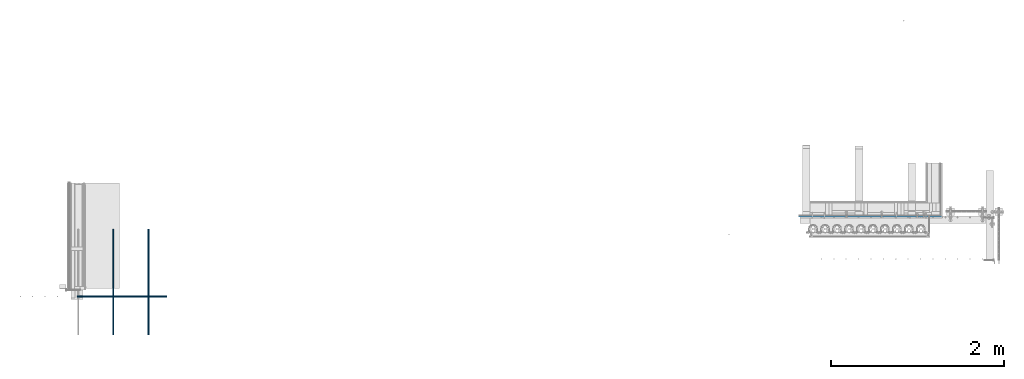
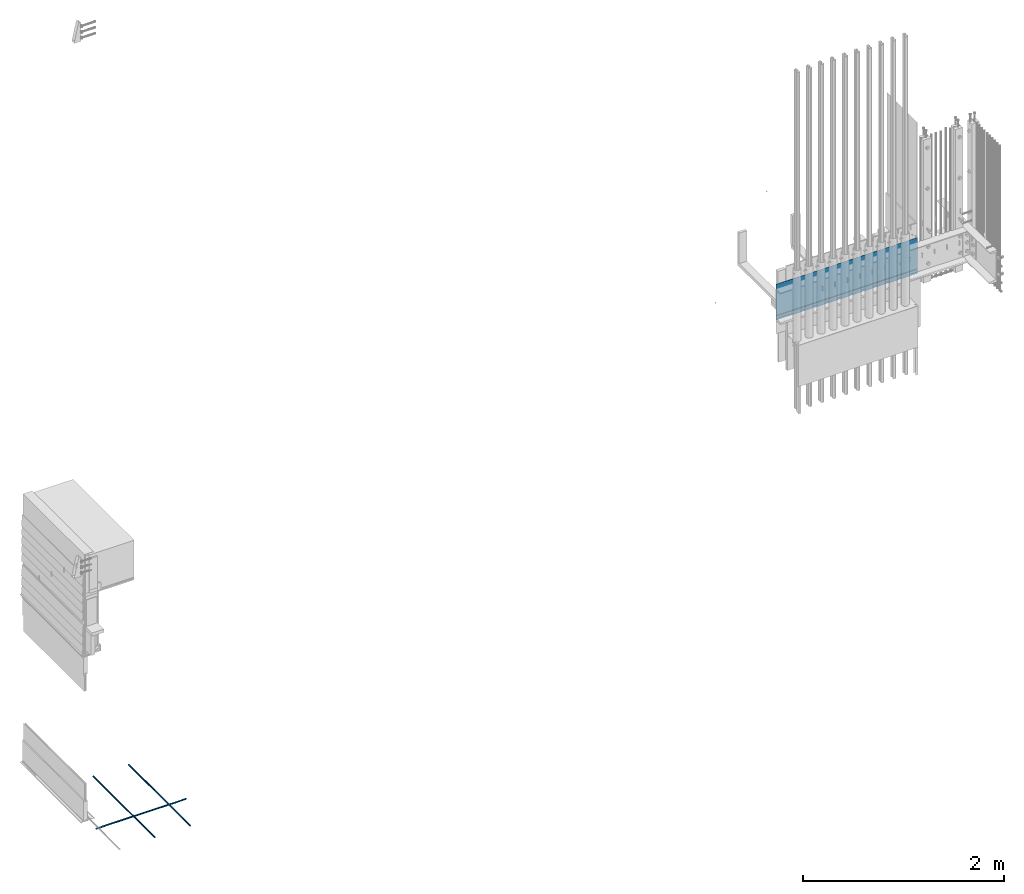
# One storey, part 4 of 44: 4 walls.
"""IFC4 building model written with IfcOpenShell, lengths in feet."""

from ifc_helpers import new_model, entity, si_unit, converted_unit, derived_unit, direction, frame, origin, place, context, subcontext, project, spatial, material, type_object, element, save


model = new_model("IFC4")

# Units and contexts
model_context = context("Model", 3, precision=0.0001, world=origin(), true_north=direction((6.12303176911189e-17, 1.0)))
body_context = subcontext(model_context, "Body", "Model", "MODEL_VIEW")
ifc_project = project(units=[converted_unit("LENGTHUNIT", "FOOT", entity("IfcRatioMeasure", 0.3048), si_unit("LENGTHUNIT", "METRE"), dimensions=[1, 0, 0, 0, 0, 0, 0]), converted_unit("AREAUNIT", "SQUARE FOOT", entity("IfcRatioMeasure", 0.09290304), si_unit("AREAUNIT", "SQUARE_METRE"), dimensions=[2, 0, 0, 0, 0, 0, 0]), converted_unit("VOLUMEUNIT", "CUBIC FOOT", entity("IfcRatioMeasure", 0.028316846592), si_unit("VOLUMEUNIT", "CUBIC_METRE"), dimensions=[3, 0, 0, 0, 0, 0, 0]), converted_unit("PLANEANGLEUNIT", "DEGREE", entity("IfcRatioMeasure", 0.0174532925199433), si_unit("PLANEANGLEUNIT", "RADIAN"), dimensions=[0, 0, 0, 0, 0, 0, 0]), si_unit("MASSUNIT", "GRAM", prefix="KILO"), derived_unit("MASSDENSITYUNIT", [(si_unit("MASSUNIT", "GRAM", prefix="KILO"), 1), (si_unit("LENGTHUNIT", "METRE"), -3)]), derived_unit("MOMENTOFINERTIAUNIT", [(si_unit("LENGTHUNIT", "METRE"), 4)]), si_unit("TIMEUNIT", "SECOND"), si_unit("FREQUENCYUNIT", "HERTZ"), si_unit("THERMODYNAMICTEMPERATUREUNIT", "DEGREE_CELSIUS"), derived_unit("THERMALTRANSMITTANCEUNIT", [(si_unit("MASSUNIT", "GRAM", prefix="KILO"), 1), (si_unit("THERMODYNAMICTEMPERATUREUNIT", "KELVIN"), -1), (si_unit("TIMEUNIT", "SECOND"), -3)]), derived_unit("VOLUMETRICFLOWRATEUNIT", [(si_unit("LENGTHUNIT", "METRE"), 3), (si_unit("TIMEUNIT", "SECOND"), -1)]), si_unit("ELECTRICCURRENTUNIT", "AMPERE"), si_unit("ELECTRICVOLTAGEUNIT", "VOLT"), si_unit("POWERUNIT", "WATT"), si_unit("FORCEUNIT", "NEWTON"), si_unit("ILLUMINANCEUNIT", "LUX"), si_unit("LUMINOUSFLUXUNIT", "LUMEN"), si_unit("LUMINOUSINTENSITYUNIT", "CANDELA"), derived_unit("USERDEFINED", [(si_unit("MASSUNIT", "GRAM", prefix="KILO"), -1), (si_unit("LENGTHUNIT", "METRE"), -2), (si_unit("TIMEUNIT", "SECOND"), 3), (si_unit("LUMINOUSFLUXUNIT", "LUMEN"), 1)]), derived_unit("LINEARVELOCITYUNIT", [(si_unit("LENGTHUNIT", "METRE"), 1), (si_unit("TIMEUNIT", "SECOND"), -1)]), si_unit("PRESSUREUNIT", "PASCAL"), derived_unit("USERDEFINED", [(si_unit("LENGTHUNIT", "METRE"), -2), (si_unit("MASSUNIT", "GRAM", prefix="KILO"), 1), (si_unit("TIMEUNIT", "SECOND"), -2)]), derived_unit("LINEARFORCEUNIT", [(si_unit("MASSUNIT", "GRAM", prefix="KILO"), 1), (si_unit("LENGTHUNIT", "METRE"), 1), (si_unit("TIMEUNIT", "SECOND"), -2), (si_unit("LENGTHUNIT", "METRE"), -1)]), derived_unit("PLANARFORCEUNIT", [(si_unit("MASSUNIT", "GRAM", prefix="KILO"), 1), (si_unit("LENGTHUNIT", "METRE"), 1), (si_unit("TIMEUNIT", "SECOND"), -2), (si_unit("LENGTHUNIT", "METRE"), -2)])], contexts=[model_context])

# Site, building, storey
site_placement = place(None, origin())
site = spatial("IfcSite", under=ifc_project, at=site_placement, CompositionType="ELEMENT")
building_placement = place(site_placement, origin())
building = spatial("IfcBuilding", under=site, at=building_placement, CompositionType="ELEMENT")
storey_placement = place(building_placement, origin())
storey = spatial("IfcBuildingStorey", under=building, at=storey_placement, CompositionType="ELEMENT", Elevation=0.0)

# Walls
ifc_material_1 = material(Category="Materials")
wall_type_1 = type_object("IfcWallType", Name="Generic Models 689:Generic Models 1", PredefinedType="NOTDEFINED", material=ifc_material_1)
wall_1_placement = place(storey_placement, frame((1459.53987375276, 1.67567612110584, -0.187500000009057)))
cartesian_point_1 = entity("IfcCartesianPoint", [0.0, 0.0208333333333333, 0.0])
vertex_point_1 = entity("IfcVertexPoint", cartesian_point_1)
cartesian_point_2 = entity("IfcCartesianPoint", [0.0, 0.0208333333333333, 0.0416666666666667])
vertex_point_2 = entity("IfcVertexPoint", cartesian_point_2)
cartesian_point_3 = entity("IfcCartesianPoint", [0.0, 0.0208333333333333, 0.0208333333333333])
ifc_direction_1 = entity("IfcDirection", [-1.0, 0.0, 0.0])
ifc_direction_2 = entity("IfcDirection", [0.0, 0.0, 1.0])
edge_curve_1 = entity("IfcEdgeCurve", vertex_point_1, vertex_point_2, entity("IfcTrimmedCurve", entity("IfcCircle", entity("IfcAxis2Placement3D", cartesian_point_3, ifc_direction_1, ifc_direction_2), 0.0208333333333333), [cartesian_point_1], [cartesian_point_2], True, "CARTESIAN"), True)
edge_curve_2 = entity("IfcEdgeCurve", vertex_point_2, vertex_point_1, entity("IfcTrimmedCurve", entity("IfcCircle", entity("IfcAxis2Placement3D", cartesian_point_3, ifc_direction_1, ifc_direction_2), 0.0208333333333333), [cartesian_point_2], [cartesian_point_1], True, "CARTESIAN"), True)
cartesian_point_4 = entity("IfcCartesianPoint", [3.393088110593, 0.0208333333333333, 0.0])
vertex_point_3 = entity("IfcVertexPoint", cartesian_point_4)
cartesian_point_5 = entity("IfcCartesianPoint", [3.393088110593, 0.0208333333333335, 0.0416666666666667])
vertex_point_4 = entity("IfcVertexPoint", cartesian_point_5)
cartesian_point_6 = entity("IfcCartesianPoint", [3.393088110593, 0.0208333333333333, 0.0208333333333333])
ifc_direction_3 = entity("IfcDirection", [1.0, 0.0, 0.0])
edge_curve_3 = entity("IfcEdgeCurve", vertex_point_3, vertex_point_4, entity("IfcTrimmedCurve", entity("IfcCircle", entity("IfcAxis2Placement3D", cartesian_point_6, ifc_direction_3, ifc_direction_2), 0.0208333333333333), [cartesian_point_4], [cartesian_point_5], True, "CARTESIAN"), True)
edge_curve_4 = entity("IfcEdgeCurve", vertex_point_4, vertex_point_3, entity("IfcTrimmedCurve", entity("IfcCircle", entity("IfcAxis2Placement3D", cartesian_point_6, ifc_direction_3, ifc_direction_2), 0.0208333333333333), [cartesian_point_5], [cartesian_point_4], True, "CARTESIAN"), True)
edge_curve_5 = entity("IfcEdgeCurve", vertex_point_3, vertex_point_1, entity("IfcTrimmedCurve", entity("IfcLine", cartesian_point_4, entity("IfcVector", ifc_direction_1, 1.0)), [cartesian_point_4], [cartesian_point_1], True, "CARTESIAN"), True)
edge_curve_6 = entity("IfcEdgeCurve", vertex_point_2, vertex_point_4, entity("IfcTrimmedCurve", entity("IfcLine", cartesian_point_5, entity("IfcVector", ifc_direction_3, 1.0)), [cartesian_point_2], [cartesian_point_5], True, "CARTESIAN"), True)
element("IfcWall", 1, at=wall_1_placement, inside=storey, type_object=wall_type_1, material=ifc_material_1, Name="Generic Models 689:Generic Models 1", ObjectType="Generic Models 689:Generic Models 1", PredefinedType="NOTDEFINED", context=body_context, shape_type="AdvancedBrep", body=[
    entity("IfcAdvancedBrep", entity("IfcClosedShell", [entity("IfcAdvancedFace", [entity("IfcFaceOuterBound", entity("IfcEdgeLoop", [entity("IfcOrientedEdge", None, None, edge_curve_1, True), entity("IfcOrientedEdge", None, None, edge_curve_2, True)]), True)], entity("IfcPlane", entity("IfcAxis2Placement3D", cartesian_point_2, ifc_direction_1, entity("IfcDirection", [0.0, 1.0, 0.0]))), True), entity("IfcAdvancedFace", [entity("IfcFaceOuterBound", entity("IfcEdgeLoop", [entity("IfcOrientedEdge", None, None, edge_curve_3, True), entity("IfcOrientedEdge", None, None, edge_curve_4, True)]), True)], entity("IfcPlane", entity("IfcAxis2Placement3D", cartesian_point_5, ifc_direction_3, entity("IfcDirection", [0.0, -1.0, 0.0]))), True), entity("IfcAdvancedFace", [entity("IfcFaceOuterBound", entity("IfcEdgeLoop", [entity("IfcOrientedEdge", None, None, edge_curve_3, False), entity("IfcOrientedEdge", None, None, edge_curve_5, True), entity("IfcOrientedEdge", None, None, edge_curve_2, False), entity("IfcOrientedEdge", None, None, edge_curve_6, True)]), True)], entity("IfcCylindricalSurface", entity("IfcAxis2Placement3D", cartesian_point_3, ifc_direction_3, ifc_direction_2), 0.0208333333333333), True), entity("IfcAdvancedFace", [entity("IfcFaceOuterBound", entity("IfcEdgeLoop", [entity("IfcOrientedEdge", None, None, edge_curve_4, False), entity("IfcOrientedEdge", None, None, edge_curve_6, False), entity("IfcOrientedEdge", None, None, edge_curve_1, False), entity("IfcOrientedEdge", None, None, edge_curve_5, False)]), True)], entity("IfcCylindricalSurface", entity("IfcAxis2Placement3D", cartesian_point_3, ifc_direction_3, ifc_direction_2), 0.0208333333333333), True)])),
])
ifc_material_2 = material(Category="Materials")
wall_type_2 = type_object("IfcWallType", Name="Generic Models 690:Generic Models 1", PredefinedType="NOTDEFINED", material=ifc_material_2)
wall_2_placement = place(storey_placement, frame((1460.89089222076, 0.240276800300759, -0.133241857409347), z_axis=(0.0, 0.0, 1.0), x_axis=(0.0, 1.0, 0.0)))
cartesian_point_7 = entity("IfcCartesianPoint", [4.009723199695, -0.0416666666665151, 0.0208333333333342])
vertex_point_5 = entity("IfcVertexPoint", cartesian_point_7)
cartesian_point_8 = entity("IfcCartesianPoint", [4.009723199695, 0.0, 0.0208333333333342])
vertex_point_6 = entity("IfcVertexPoint", cartesian_point_8)
cartesian_point_9 = entity("IfcCartesianPoint", [4.009723199695, -0.0208333333332575, 0.0208333333333342])
ifc_direction_4 = entity("IfcDirection", [1.0, 0.0, 0.0])
ifc_direction_5 = entity("IfcDirection", [0.0, 1.0, 0.0])
edge_curve_7 = entity("IfcEdgeCurve", vertex_point_5, vertex_point_6, entity("IfcTrimmedCurve", entity("IfcCircle", entity("IfcAxis2Placement3D", cartesian_point_9, ifc_direction_4, ifc_direction_5), 0.0208333333333333), [cartesian_point_7], [cartesian_point_8], True, "CARTESIAN"), True)
edge_curve_8 = entity("IfcEdgeCurve", vertex_point_6, vertex_point_5, entity("IfcTrimmedCurve", entity("IfcCircle", entity("IfcAxis2Placement3D", cartesian_point_9, ifc_direction_4, ifc_direction_5), 0.0208333333333333), [cartesian_point_8], [cartesian_point_7], True, "CARTESIAN"), True)
cartesian_point_10 = entity("IfcCartesianPoint", [0.0, -0.0416666666665151, 0.0208333333333333])
vertex_point_7 = entity("IfcVertexPoint", cartesian_point_10)
cartesian_point_11 = entity("IfcCartesianPoint", [0.0, 0.0, 0.0208333333333334])
vertex_point_8 = entity("IfcVertexPoint", cartesian_point_11)
cartesian_point_12 = entity("IfcCartesianPoint", [0.0, -0.0208333333332575, 0.0208333333333333])
ifc_direction_6 = entity("IfcDirection", [-1.0, 0.0, 0.0])
edge_curve_9 = entity("IfcEdgeCurve", vertex_point_7, vertex_point_8, entity("IfcTrimmedCurve", entity("IfcCircle", entity("IfcAxis2Placement3D", cartesian_point_12, ifc_direction_6, ifc_direction_5), 0.0208333333333333), [cartesian_point_10], [cartesian_point_11], True, "CARTESIAN"), True)
edge_curve_10 = entity("IfcEdgeCurve", vertex_point_8, vertex_point_7, entity("IfcTrimmedCurve", entity("IfcCircle", entity("IfcAxis2Placement3D", cartesian_point_12, ifc_direction_6, ifc_direction_5), 0.0208333333333333), [cartesian_point_11], [cartesian_point_10], True, "CARTESIAN"), True)
edge_curve_11 = entity("IfcEdgeCurve", vertex_point_8, vertex_point_6, entity("IfcTrimmedCurve", entity("IfcLine", cartesian_point_11, entity("IfcVector", ifc_direction_4, 1.0)), [cartesian_point_11], [cartesian_point_8], True, "CARTESIAN"), True)
edge_curve_12 = entity("IfcEdgeCurve", vertex_point_5, vertex_point_7, entity("IfcTrimmedCurve", entity("IfcLine", cartesian_point_10, entity("IfcVector", ifc_direction_6, 1.0)), [cartesian_point_7], [cartesian_point_10], True, "CARTESIAN"), True)
element("IfcWall", 2, at=wall_2_placement, inside=storey, type_object=wall_type_2, material=ifc_material_2, Name="Generic Models 690:Generic Models 1", ObjectType="Generic Models 690:Generic Models 1", PredefinedType="NOTDEFINED", context=body_context, shape_type="AdvancedBrep", body=[
    entity("IfcAdvancedBrep", entity("IfcClosedShell", [entity("IfcAdvancedFace", [entity("IfcFaceOuterBound", entity("IfcEdgeLoop", [entity("IfcOrientedEdge", None, None, edge_curve_7, True), entity("IfcOrientedEdge", None, None, edge_curve_8, True)]), True)], entity("IfcPlane", entity("IfcAxis2Placement3D", cartesian_point_8, ifc_direction_4, entity("IfcDirection", [0.0, 0.0, 1.0]))), True), entity("IfcAdvancedFace", [entity("IfcFaceOuterBound", entity("IfcEdgeLoop", [entity("IfcOrientedEdge", None, None, edge_curve_9, True), entity("IfcOrientedEdge", None, None, edge_curve_10, True)]), True)], entity("IfcPlane", entity("IfcAxis2Placement3D", cartesian_point_11, ifc_direction_6, entity("IfcDirection", [0.0, 0.0, -1.0]))), True), entity("IfcAdvancedFace", [entity("IfcFaceOuterBound", entity("IfcEdgeLoop", [entity("IfcOrientedEdge", None, None, edge_curve_10, False), entity("IfcOrientedEdge", None, None, edge_curve_11, True), entity("IfcOrientedEdge", None, None, edge_curve_7, False), entity("IfcOrientedEdge", None, None, edge_curve_12, True)]), True)], entity("IfcCylindricalSurface", entity("IfcAxis2Placement3D", cartesian_point_9, ifc_direction_6, ifc_direction_5), 0.0208333333333333), True), entity("IfcAdvancedFace", [entity("IfcFaceOuterBound", entity("IfcEdgeLoop", [entity("IfcOrientedEdge", None, None, edge_curve_9, False), entity("IfcOrientedEdge", None, None, edge_curve_12, False), entity("IfcOrientedEdge", None, None, edge_curve_8, False), entity("IfcOrientedEdge", None, None, edge_curve_11, False)]), True)], entity("IfcCylindricalSurface", entity("IfcAxis2Placement3D", cartesian_point_9, ifc_direction_6, ifc_direction_5), 0.0208333333333333), True)])),
])
wall_type_3 = type_object("IfcWallType", Name="Generic Models 692:Generic Models 1", PredefinedType="NOTDEFINED", material=ifc_material_2)
wall_3_placement = place(storey_placement, frame((1462.22422555409, 0.240276800300755, -0.133241857409355), z_axis=(0.0, 0.0, 1.0), x_axis=(0.0, 1.0, 0.0)))
cartesian_point_13 = entity("IfcCartesianPoint", [4.009723199695, -0.0416666666665151, 0.0208333333333342])
vertex_point_9 = entity("IfcVertexPoint", cartesian_point_13)
cartesian_point_14 = entity("IfcCartesianPoint", [4.009723199695, 0.0, 0.0208333333333342])
vertex_point_10 = entity("IfcVertexPoint", cartesian_point_14)
cartesian_point_15 = entity("IfcCartesianPoint", [4.009723199695, -0.0208333333332575, 0.0208333333333342])
ifc_direction_7 = entity("IfcDirection", [1.0, 0.0, 0.0])
ifc_direction_8 = entity("IfcDirection", [0.0, 1.0, 0.0])
edge_curve_13 = entity("IfcEdgeCurve", vertex_point_9, vertex_point_10, entity("IfcTrimmedCurve", entity("IfcCircle", entity("IfcAxis2Placement3D", cartesian_point_15, ifc_direction_7, ifc_direction_8), 0.0208333333333333), [cartesian_point_13], [cartesian_point_14], True, "CARTESIAN"), True)
edge_curve_14 = entity("IfcEdgeCurve", vertex_point_10, vertex_point_9, entity("IfcTrimmedCurve", entity("IfcCircle", entity("IfcAxis2Placement3D", cartesian_point_15, ifc_direction_7, ifc_direction_8), 0.0208333333333333), [cartesian_point_14], [cartesian_point_13], True, "CARTESIAN"), True)
cartesian_point_16 = entity("IfcCartesianPoint", [0.0, -0.0416666666665151, 0.0208333333333333])
vertex_point_11 = entity("IfcVertexPoint", cartesian_point_16)
cartesian_point_17 = entity("IfcCartesianPoint", [0.0, 0.0, 0.0208333333333335])
vertex_point_12 = entity("IfcVertexPoint", cartesian_point_17)
cartesian_point_18 = entity("IfcCartesianPoint", [0.0, -0.0208333333332575, 0.0208333333333333])
ifc_direction_9 = entity("IfcDirection", [-1.0, 0.0, 0.0])
edge_curve_15 = entity("IfcEdgeCurve", vertex_point_11, vertex_point_12, entity("IfcTrimmedCurve", entity("IfcCircle", entity("IfcAxis2Placement3D", cartesian_point_18, ifc_direction_9, ifc_direction_8), 0.0208333333333333), [cartesian_point_16], [cartesian_point_17], True, "CARTESIAN"), True)
edge_curve_16 = entity("IfcEdgeCurve", vertex_point_12, vertex_point_11, entity("IfcTrimmedCurve", entity("IfcCircle", entity("IfcAxis2Placement3D", cartesian_point_18, ifc_direction_9, ifc_direction_8), 0.0208333333333333), [cartesian_point_17], [cartesian_point_16], True, "CARTESIAN"), True)
edge_curve_17 = entity("IfcEdgeCurve", vertex_point_12, vertex_point_10, entity("IfcTrimmedCurve", entity("IfcLine", cartesian_point_17, entity("IfcVector", ifc_direction_7, 1.0)), [cartesian_point_17], [cartesian_point_14], True, "CARTESIAN"), True)
edge_curve_18 = entity("IfcEdgeCurve", vertex_point_9, vertex_point_11, entity("IfcTrimmedCurve", entity("IfcLine", cartesian_point_16, entity("IfcVector", ifc_direction_9, 1.0)), [cartesian_point_13], [cartesian_point_16], True, "CARTESIAN"), True)
element("IfcWall", 3, at=wall_3_placement, inside=storey, type_object=wall_type_3, material=ifc_material_2, Name="Generic Models 692:Generic Models 1", ObjectType="Generic Models 692:Generic Models 1", PredefinedType="NOTDEFINED", context=body_context, shape_type="AdvancedBrep", body=[
    entity("IfcAdvancedBrep", entity("IfcClosedShell", [entity("IfcAdvancedFace", [entity("IfcFaceOuterBound", entity("IfcEdgeLoop", [entity("IfcOrientedEdge", None, None, edge_curve_13, True), entity("IfcOrientedEdge", None, None, edge_curve_14, True)]), True)], entity("IfcPlane", entity("IfcAxis2Placement3D", cartesian_point_14, ifc_direction_7, entity("IfcDirection", [0.0, 0.0, 1.0]))), True), entity("IfcAdvancedFace", [entity("IfcFaceOuterBound", entity("IfcEdgeLoop", [entity("IfcOrientedEdge", None, None, edge_curve_15, True), entity("IfcOrientedEdge", None, None, edge_curve_16, True)]), True)], entity("IfcPlane", entity("IfcAxis2Placement3D", cartesian_point_17, ifc_direction_9, entity("IfcDirection", [0.0, 0.0, -1.0]))), True), entity("IfcAdvancedFace", [entity("IfcFaceOuterBound", entity("IfcEdgeLoop", [entity("IfcOrientedEdge", None, None, edge_curve_16, False), entity("IfcOrientedEdge", None, None, edge_curve_17, True), entity("IfcOrientedEdge", None, None, edge_curve_13, False), entity("IfcOrientedEdge", None, None, edge_curve_18, True)]), True)], entity("IfcCylindricalSurface", entity("IfcAxis2Placement3D", cartesian_point_15, ifc_direction_9, ifc_direction_8), 0.0208333333333333), True), entity("IfcAdvancedFace", [entity("IfcFaceOuterBound", entity("IfcEdgeLoop", [entity("IfcOrientedEdge", None, None, edge_curve_15, False), entity("IfcOrientedEdge", None, None, edge_curve_18, False), entity("IfcOrientedEdge", None, None, edge_curve_14, False), entity("IfcOrientedEdge", None, None, edge_curve_17, False)]), True)], entity("IfcCylindricalSurface", entity("IfcAxis2Placement3D", cartesian_point_15, ifc_direction_9, ifc_direction_8), 0.0208333333333333), True)])),
])
ifc_material_3 = material(Name="BUILDING WRAP", Category="Materials")
wall_type_4 = type_object("IfcWallType", Name="Generic Models 720:Generic Models 1", PredefinedType="NOTDEFINED", material=ifc_material_3)
wall_4_placement = place(storey_placement, frame((1486.94745796881, 4.73942156338219, 8.67192049060858)))
cartesian_point_19 = entity("IfcCartesianPoint", [5.33247256279287, 0.010311509054536, 0.18249161117128])
vertex_point_13 = entity("IfcVertexPoint", cartesian_point_19)
cartesian_point_20 = entity("IfcCartesianPoint", [5.33247256279287, 0.010311509054536, 1.42642344808554])
vertex_point_14 = entity("IfcVertexPoint", cartesian_point_20)
ifc_direction_10 = entity("IfcDirection", [0.0, 0.0, 1.0])
edge_curve_19 = entity("IfcEdgeCurve", vertex_point_13, vertex_point_14, entity("IfcTrimmedCurve", entity("IfcLine", cartesian_point_19, entity("IfcVector", ifc_direction_10, 1.0)), [cartesian_point_19], [cartesian_point_20], True, "CARTESIAN"), True)
cartesian_point_21 = entity("IfcCartesianPoint", [5.33247256279287, 0.00696430771753587, 1.42642344808554])
vertex_point_15 = entity("IfcVertexPoint", cartesian_point_21)
ifc_direction_11 = entity("IfcDirection", [0.0, -1.0, 0.0])
edge_curve_20 = entity("IfcEdgeCurve", vertex_point_14, vertex_point_15, entity("IfcTrimmedCurve", entity("IfcLine", cartesian_point_20, entity("IfcVector", ifc_direction_11, 1.0)), [cartesian_point_20], [cartesian_point_21], True, "CARTESIAN"), True)
cartesian_point_22 = entity("IfcCartesianPoint", [5.33247256279287, 0.00696430771753587, 0.181902421725766])
vertex_point_16 = entity("IfcVertexPoint", cartesian_point_22)
ifc_direction_12 = entity("IfcDirection", [0.0, 0.0, -1.0])
edge_curve_21 = entity("IfcEdgeCurve", vertex_point_15, vertex_point_16, entity("IfcTrimmedCurve", entity("IfcLine", cartesian_point_21, entity("IfcVector", ifc_direction_12, 1.0)), [cartesian_point_21], [cartesian_point_22], True, "CARTESIAN"), True)
cartesian_point_23 = entity("IfcCartesianPoint", [5.33247256279287, 0.0, 0.169839886919451])
vertex_point_17 = entity("IfcVertexPoint", cartesian_point_23)
edge_curve_22 = entity("IfcEdgeCurve", vertex_point_16, vertex_point_17, entity("IfcTrimmedCurve", entity("IfcLine", cartesian_point_22, entity("IfcVector", entity("IfcDirection", [0.0, -0.49999999999998, -0.86602540378445]), 1.0)), [cartesian_point_22], [cartesian_point_23], True, "CARTESIAN"), True)
cartesian_point_24 = entity("IfcCartesianPoint", [5.33247256279287, 0.0, 0.0])
vertex_point_18 = entity("IfcVertexPoint", cartesian_point_24)
edge_curve_23 = entity("IfcEdgeCurve", vertex_point_17, vertex_point_18, entity("IfcTrimmedCurve", entity("IfcLine", cartesian_point_23, entity("IfcVector", ifc_direction_12, 1.0)), [cartesian_point_23], [cartesian_point_24], True, "CARTESIAN"), True)
cartesian_point_25 = entity("IfcCartesianPoint", [5.33247256279287, 0.00260416666666696, 0.0])
vertex_point_19 = entity("IfcVertexPoint", cartesian_point_25)
ifc_direction_13 = entity("IfcDirection", [0.0, 1.0, 0.0])
edge_curve_24 = entity("IfcEdgeCurve", vertex_point_18, vertex_point_19, entity("IfcTrimmedCurve", entity("IfcLine", cartesian_point_24, entity("IfcVector", ifc_direction_13, 1.0)), [cartesian_point_24], [cartesian_point_25], True, "CARTESIAN"), True)
cartesian_point_26 = entity("IfcCartesianPoint", [5.33247256279287, 0.00260416666666696, 0.169142102564162])
vertex_point_20 = entity("IfcVertexPoint", cartesian_point_26)
edge_curve_25 = entity("IfcEdgeCurve", vertex_point_19, vertex_point_20, entity("IfcTrimmedCurve", entity("IfcLine", cartesian_point_25, entity("IfcVector", ifc_direction_10, 1.0)), [cartesian_point_25], [cartesian_point_26], True, "CARTESIAN"), True)
edge_curve_26 = entity("IfcEdgeCurve", vertex_point_20, vertex_point_13, entity("IfcTrimmedCurve", entity("IfcLine", cartesian_point_26, entity("IfcVector", entity("IfcDirection", [0.0, 0.499999999999944, 0.866025403784471]), 1.0)), [cartesian_point_26], [cartesian_point_19], True, "CARTESIAN"), True)
ifc_direction_14 = entity("IfcDirection", [1.0, 0.0, 0.0])
cartesian_point_27 = entity("IfcCartesianPoint", [0.0, 0.010311509054624, 0.18249161117129])
vertex_point_21 = entity("IfcVertexPoint", cartesian_point_27)
cartesian_point_28 = entity("IfcCartesianPoint", [0.0, 0.00260416666675578, 0.169142102564171])
vertex_point_22 = entity("IfcVertexPoint", cartesian_point_28)
edge_curve_27 = entity("IfcEdgeCurve", vertex_point_21, vertex_point_22, entity("IfcTrimmedCurve", entity("IfcLine", cartesian_point_27, entity("IfcVector", entity("IfcDirection", [0.0, -0.499999999999944, -0.866025403784471]), 1.0)), [cartesian_point_27], [cartesian_point_28], True, "CARTESIAN"), True)
cartesian_point_29 = entity("IfcCartesianPoint", [0.0, 0.00260416666675489, 0.0])
vertex_point_23 = entity("IfcVertexPoint", cartesian_point_29)
edge_curve_28 = entity("IfcEdgeCurve", vertex_point_22, vertex_point_23, entity("IfcTrimmedCurve", entity("IfcLine", cartesian_point_28, entity("IfcVector", ifc_direction_12, 1.0)), [cartesian_point_28], [cartesian_point_29], True, "CARTESIAN"), True)
cartesian_point_30 = entity("IfcCartesianPoint", [0.0, 0.0, 0.0])
vertex_point_24 = entity("IfcVertexPoint", cartesian_point_30)
edge_curve_29 = entity("IfcEdgeCurve", vertex_point_23, vertex_point_24, entity("IfcTrimmedCurve", entity("IfcLine", cartesian_point_29, entity("IfcVector", ifc_direction_11, 1.0)), [cartesian_point_29], [cartesian_point_30], True, "CARTESIAN"), True)
cartesian_point_31 = entity("IfcCartesianPoint", [0.0, 0.0, 0.16983988691946])
vertex_point_25 = entity("IfcVertexPoint", cartesian_point_31)
edge_curve_30 = entity("IfcEdgeCurve", vertex_point_24, vertex_point_25, entity("IfcTrimmedCurve", entity("IfcLine", cartesian_point_30, entity("IfcVector", ifc_direction_10, 1.0)), [cartesian_point_30], [cartesian_point_31], True, "CARTESIAN"), True)
cartesian_point_32 = entity("IfcCartesianPoint", [0.0, 0.0069643077176238, 0.181902421725777])
vertex_point_26 = entity("IfcVertexPoint", cartesian_point_32)
edge_curve_31 = entity("IfcEdgeCurve", vertex_point_25, vertex_point_26, entity("IfcTrimmedCurve", entity("IfcLine", cartesian_point_31, entity("IfcVector", entity("IfcDirection", [0.0, 0.49999999999998, 0.86602540378445]), 1.0)), [cartesian_point_31], [cartesian_point_32], True, "CARTESIAN"), True)
cartesian_point_33 = entity("IfcCartesianPoint", [0.0, 0.0069643077176238, 1.42642344808555])
vertex_point_27 = entity("IfcVertexPoint", cartesian_point_33)
edge_curve_32 = entity("IfcEdgeCurve", vertex_point_26, vertex_point_27, entity("IfcTrimmedCurve", entity("IfcLine", cartesian_point_32, entity("IfcVector", ifc_direction_10, 1.0)), [cartesian_point_32], [cartesian_point_33], True, "CARTESIAN"), True)
cartesian_point_34 = entity("IfcCartesianPoint", [0.0, 0.010311509054624, 1.42642344808555])
vertex_point_28 = entity("IfcVertexPoint", cartesian_point_34)
edge_curve_33 = entity("IfcEdgeCurve", vertex_point_27, vertex_point_28, entity("IfcTrimmedCurve", entity("IfcLine", cartesian_point_33, entity("IfcVector", ifc_direction_13, 1.0)), [cartesian_point_33], [cartesian_point_34], True, "CARTESIAN"), True)
edge_curve_34 = entity("IfcEdgeCurve", vertex_point_28, vertex_point_21, entity("IfcTrimmedCurve", entity("IfcLine", cartesian_point_34, entity("IfcVector", ifc_direction_12, 1.0)), [cartesian_point_34], [cartesian_point_27], True, "CARTESIAN"), True)
ifc_direction_15 = entity("IfcDirection", [-1.0, 0.0, 0.0])
edge_curve_35 = entity("IfcEdgeCurve", vertex_point_21, vertex_point_13, entity("IfcTrimmedCurve", entity("IfcLine", cartesian_point_27, entity("IfcVector", ifc_direction_14, 1.0)), [cartesian_point_27], [cartesian_point_19], True, "CARTESIAN"), True)
edge_curve_36 = entity("IfcEdgeCurve", vertex_point_20, vertex_point_22, entity("IfcTrimmedCurve", entity("IfcLine", cartesian_point_28, entity("IfcVector", ifc_direction_15, 1.0)), [cartesian_point_26], [cartesian_point_28], True, "CARTESIAN"), True)
edge_curve_37 = entity("IfcEdgeCurve", vertex_point_19, vertex_point_23, entity("IfcTrimmedCurve", entity("IfcLine", cartesian_point_29, entity("IfcVector", ifc_direction_15, 1.0)), [cartesian_point_25], [cartesian_point_29], True, "CARTESIAN"), True)
edge_curve_38 = entity("IfcEdgeCurve", vertex_point_18, vertex_point_24, entity("IfcTrimmedCurve", entity("IfcLine", cartesian_point_30, entity("IfcVector", ifc_direction_15, 1.0)), [cartesian_point_24], [cartesian_point_30], True, "CARTESIAN"), True)
edge_curve_39 = entity("IfcEdgeCurve", vertex_point_27, vertex_point_15, entity("IfcTrimmedCurve", entity("IfcLine", cartesian_point_33, entity("IfcVector", ifc_direction_14, 1.0)), [cartesian_point_33], [cartesian_point_21], True, "CARTESIAN"), True)
edge_curve_40 = entity("IfcEdgeCurve", vertex_point_14, vertex_point_28, entity("IfcTrimmedCurve", entity("IfcLine", cartesian_point_34, entity("IfcVector", ifc_direction_15, 1.0)), [cartesian_point_20], [cartesian_point_34], True, "CARTESIAN"), True)
edge_curve_41 = entity("IfcEdgeCurve", vertex_point_17, vertex_point_25, entity("IfcTrimmedCurve", entity("IfcLine", cartesian_point_31, entity("IfcVector", ifc_direction_15, 1.0)), [cartesian_point_23], [cartesian_point_31], True, "CARTESIAN"), True)
edge_curve_42 = entity("IfcEdgeCurve", vertex_point_16, vertex_point_26, entity("IfcTrimmedCurve", entity("IfcLine", cartesian_point_32, entity("IfcVector", ifc_direction_15, 1.0)), [cartesian_point_22], [cartesian_point_32], True, "CARTESIAN"), True)
element("IfcWall", 4, at=wall_4_placement, inside=storey, type_object=wall_type_4, material=ifc_material_3, Name="Generic Models 720:Generic Models 1", ObjectType="Generic Models 720:Generic Models 1", PredefinedType="NOTDEFINED", context=body_context, shape_type="AdvancedBrep", body=[
    entity("IfcAdvancedBrep", entity("IfcClosedShell", [entity("IfcAdvancedFace", [entity("IfcFaceOuterBound", entity("IfcEdgeLoop", [entity("IfcOrientedEdge", None, None, edge_curve_19, True), entity("IfcOrientedEdge", None, None, edge_curve_20, True), entity("IfcOrientedEdge", None, None, edge_curve_21, True), entity("IfcOrientedEdge", None, None, edge_curve_22, True), entity("IfcOrientedEdge", None, None, edge_curve_23, True), entity("IfcOrientedEdge", None, None, edge_curve_24, True), entity("IfcOrientedEdge", None, None, edge_curve_25, True), entity("IfcOrientedEdge", None, None, edge_curve_26, True)]), True)], entity("IfcPlane", entity("IfcAxis2Placement3D", entity("IfcCartesianPoint", [5.33247256279287, -0.0571365003799729, 0.0656682319613218]), ifc_direction_14, entity("IfcDirection", [0.0, 0.499999999999987, 0.866025403784446]))), True), entity("IfcAdvancedFace", [entity("IfcFaceOuterBound", entity("IfcEdgeLoop", [entity("IfcOrientedEdge", None, None, edge_curve_27, True), entity("IfcOrientedEdge", None, None, edge_curve_28, True), entity("IfcOrientedEdge", None, None, edge_curve_29, True), entity("IfcOrientedEdge", None, None, edge_curve_30, True), entity("IfcOrientedEdge", None, None, edge_curve_31, True), entity("IfcOrientedEdge", None, None, edge_curve_32, True), entity("IfcOrientedEdge", None, None, edge_curve_33, True), entity("IfcOrientedEdge", None, None, edge_curve_34, True)]), True)], entity("IfcPlane", entity("IfcAxis2Placement3D", entity("IfcCartesianPoint", [0.0, -0.0571365003798849, 0.0656682319613306]), ifc_direction_15, entity("IfcDirection", [0.0, -0.499999999999987, -0.866025403784446]))), True), entity("IfcAdvancedFace", [entity("IfcFaceOuterBound", entity("IfcEdgeLoop", [entity("IfcOrientedEdge", None, None, edge_curve_27, False), entity("IfcOrientedEdge", None, None, edge_curve_35, True), entity("IfcOrientedEdge", None, None, edge_curve_26, False), entity("IfcOrientedEdge", None, None, edge_curve_36, True)]), True)], entity("IfcPlane", entity("IfcAxis2Placement3D", cartesian_point_27, entity("IfcDirection", [0.0, 0.866025403784446, -0.499999999999987]), ifc_direction_14)), True), entity("IfcAdvancedFace", [entity("IfcFaceOuterBound", entity("IfcEdgeLoop", [entity("IfcOrientedEdge", None, None, edge_curve_28, False), entity("IfcOrientedEdge", None, None, edge_curve_36, False), entity("IfcOrientedEdge", None, None, edge_curve_25, False), entity("IfcOrientedEdge", None, None, edge_curve_37, True)]), True)], entity("IfcPlane", entity("IfcAxis2Placement3D", cartesian_point_28, ifc_direction_13, ifc_direction_14)), True), entity("IfcAdvancedFace", [entity("IfcFaceOuterBound", entity("IfcEdgeLoop", [entity("IfcOrientedEdge", None, None, edge_curve_29, False), entity("IfcOrientedEdge", None, None, edge_curve_37, False), entity("IfcOrientedEdge", None, None, edge_curve_24, False), entity("IfcOrientedEdge", None, None, edge_curve_38, True)]), True)], entity("IfcPlane", entity("IfcAxis2Placement3D", cartesian_point_29, ifc_direction_12, ifc_direction_14)), True), entity("IfcAdvancedFace", [entity("IfcFaceOuterBound", entity("IfcEdgeLoop", [entity("IfcOrientedEdge", None, None, edge_curve_33, False), entity("IfcOrientedEdge", None, None, edge_curve_39, True), entity("IfcOrientedEdge", None, None, edge_curve_20, False), entity("IfcOrientedEdge", None, None, edge_curve_40, True)]), True)], entity("IfcPlane", entity("IfcAxis2Placement3D", cartesian_point_33, ifc_direction_10, ifc_direction_14)), True), entity("IfcAdvancedFace", [entity("IfcFaceOuterBound", entity("IfcEdgeLoop", [entity("IfcOrientedEdge", None, None, edge_curve_34, False), entity("IfcOrientedEdge", None, None, edge_curve_40, False), entity("IfcOrientedEdge", None, None, edge_curve_19, False), entity("IfcOrientedEdge", None, None, edge_curve_35, False)]), True)], entity("IfcPlane", entity("IfcAxis2Placement3D", cartesian_point_34, ifc_direction_13, ifc_direction_14)), True), entity("IfcAdvancedFace", [entity("IfcFaceOuterBound", entity("IfcEdgeLoop", [entity("IfcOrientedEdge", None, None, edge_curve_30, False), entity("IfcOrientedEdge", None, None, edge_curve_38, False), entity("IfcOrientedEdge", None, None, edge_curve_23, False), entity("IfcOrientedEdge", None, None, edge_curve_41, True)]), True)], entity("IfcPlane", entity("IfcAxis2Placement3D", cartesian_point_30, ifc_direction_11, ifc_direction_14)), True), entity("IfcAdvancedFace", [entity("IfcFaceOuterBound", entity("IfcEdgeLoop", [entity("IfcOrientedEdge", None, None, edge_curve_31, False), entity("IfcOrientedEdge", None, None, edge_curve_41, False), entity("IfcOrientedEdge", None, None, edge_curve_22, False), entity("IfcOrientedEdge", None, None, edge_curve_42, True)]), True)], entity("IfcPlane", entity("IfcAxis2Placement3D", cartesian_point_31, entity("IfcDirection", [0.0, -0.86602540378445, 0.49999999999998]), ifc_direction_14)), True), entity("IfcAdvancedFace", [entity("IfcFaceOuterBound", entity("IfcEdgeLoop", [entity("IfcOrientedEdge", None, None, edge_curve_32, False), entity("IfcOrientedEdge", None, None, edge_curve_42, False), entity("IfcOrientedEdge", None, None, edge_curve_21, False), entity("IfcOrientedEdge", None, None, edge_curve_39, False)]), True)], entity("IfcPlane", entity("IfcAxis2Placement3D", cartesian_point_32, ifc_direction_11, ifc_direction_14)), True)])),
])

save(model, "model.ifc")
